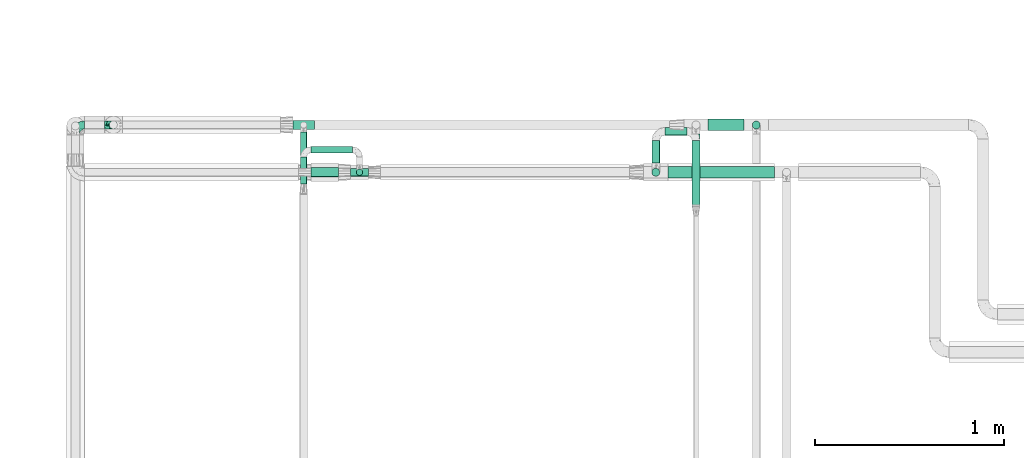
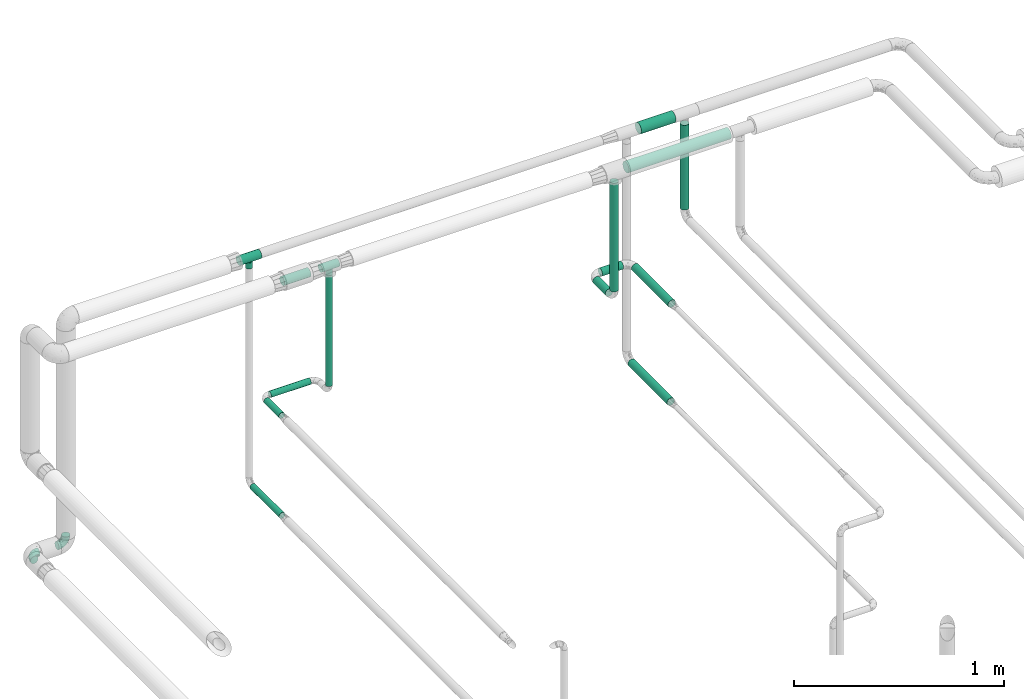
# One storey, part 580 of 824: 13 flow segments, 4 flow fittings.
"""IFC2X3 building model written with IfcOpenShell, lengths in millimetres."""

from ifc_helpers import new_model, entity, si_unit, converted_unit, derived_unit, direction, frame, origin, origin_2d_with_axis, place, context, subcontext, project, spatial, circle, extrude, faceted_brep, source, transform, mapped, material, type_object, type_shapes, element, save


model = new_model("IFC2X3")

# Units and contexts
model_context = context("Model", 3, precision=0.01, world=origin(), true_north=direction((6.12303176911189e-17, 1.0)))
body_context = subcontext(model_context, "Body", "Model", "MODEL_VIEW")
ifc_project = project(units=[si_unit("LENGTHUNIT", "METRE", prefix="MILLI"), si_unit("AREAUNIT", "SQUARE_METRE"), si_unit("VOLUMEUNIT", "CUBIC_METRE"), converted_unit("PLANEANGLEUNIT", "DEGREE", entity("IfcRatioMeasure", 0.0174532925199433), si_unit("PLANEANGLEUNIT", "RADIAN"), dimensions=[0, 0, 0, 0, 0, 0, 0]), si_unit("MASSUNIT", "GRAM", prefix="KILO"), derived_unit("MASSDENSITYUNIT", [(si_unit("MASSUNIT", "GRAM", prefix="KILO"), 1), (si_unit("LENGTHUNIT", "METRE"), -3)]), derived_unit("MOMENTOFINERTIAUNIT", [(si_unit("LENGTHUNIT", "METRE"), 4)]), si_unit("TIMEUNIT", "SECOND"), si_unit("FREQUENCYUNIT", "HERTZ"), si_unit("THERMODYNAMICTEMPERATUREUNIT", "DEGREE_CELSIUS"), derived_unit("THERMALTRANSMITTANCEUNIT", [(si_unit("MASSUNIT", "GRAM", prefix="KILO"), 1), (si_unit("THERMODYNAMICTEMPERATUREUNIT", "KELVIN"), -1), (si_unit("TIMEUNIT", "SECOND"), -3)]), derived_unit("VOLUMETRICFLOWRATEUNIT", [(si_unit("LENGTHUNIT", "METRE"), 3), (si_unit("TIMEUNIT", "SECOND"), -1)]), derived_unit("MASSFLOWRATEUNIT", [(si_unit("MASSUNIT", "GRAM", prefix="KILO"), 1), (si_unit("TIMEUNIT", "SECOND"), -1)]), derived_unit("ROTATIONALFREQUENCYUNIT", [(si_unit("TIMEUNIT", "SECOND"), -1)]), si_unit("ELECTRICCURRENTUNIT", "AMPERE"), si_unit("ELECTRICVOLTAGEUNIT", "VOLT"), si_unit("POWERUNIT", "WATT"), si_unit("FORCEUNIT", "NEWTON", prefix="KILO"), si_unit("ILLUMINANCEUNIT", "LUX"), si_unit("LUMINOUSFLUXUNIT", "LUMEN"), si_unit("LUMINOUSINTENSITYUNIT", "CANDELA"), derived_unit("USERDEFINED", [(si_unit("MASSUNIT", "GRAM", prefix="KILO"), -1), (si_unit("LENGTHUNIT", "METRE"), -2), (si_unit("TIMEUNIT", "SECOND"), 3), (si_unit("LUMINOUSFLUXUNIT", "LUMEN"), 1)]), derived_unit("LINEARVELOCITYUNIT", [(si_unit("LENGTHUNIT", "METRE"), 1), (si_unit("TIMEUNIT", "SECOND"), -1)]), si_unit("PRESSUREUNIT", "PASCAL"), derived_unit("USERDEFINED", [(si_unit("LENGTHUNIT", "METRE"), -2), (si_unit("MASSUNIT", "GRAM", prefix="KILO"), 1), (si_unit("TIMEUNIT", "SECOND"), -2)]), derived_unit("LINEARFORCEUNIT", [(si_unit("MASSUNIT", "GRAM", prefix="KILO"), 1), (si_unit("LENGTHUNIT", "METRE"), 1), (si_unit("TIMEUNIT", "SECOND"), -2), (si_unit("LENGTHUNIT", "METRE"), -1)]), derived_unit("PLANARFORCEUNIT", [(si_unit("MASSUNIT", "GRAM", prefix="KILO"), 1), (si_unit("LENGTHUNIT", "METRE"), 1), (si_unit("TIMEUNIT", "SECOND"), -2), (si_unit("LENGTHUNIT", "METRE"), -2)])], contexts=[model_context])

# Site, building, storey
site_placement = place(None, origin())
site = spatial("IfcSite", under=ifc_project, at=site_placement, CompositionType="ELEMENT")
building_placement = place(site_placement, origin())
building = spatial("IfcBuilding", under=site, at=building_placement, CompositionType="ELEMENT")
storey_placement = place(building_placement, frame((0.0, 0.0, 28200.0)))
storey = spatial("IfcBuildingStorey", under=building, at=storey_placement, CompositionType="ELEMENT", Elevation=28200.0)

# Flow segments
pipe_segment_type = type_object("IfcPipeSegmentType", PredefinedType="NOTDEFINED")
flow_segment_1_placement = place(storey_placement, frame((15048.15, 18810.97, 2242.71)))
element("IfcFlowSegment", 1, at=flow_segment_1_placement, inside=storey, type_object=pipe_segment_type, context=body_context, shape_type="SweptSolid", body=[
    extrude(circle(Radius=21.15, at=origin_2d_with_axis()), frame((22.75, 0.0, 22.75), z_axis=(0.0, 1.0, 0.0), x_axis=(1.0, 0.0, 0.0)), (0.0, 0.0, 1.0), 120.142381818539),
])
flow_segment_2_placement = place(storey_placement, frame((15118.9, 18956.37, 2242.71)))
element("IfcFlowSegment", 2, at=flow_segment_2_placement, inside=storey, type_object=pipe_segment_type, context=body_context, shape_type="SweptSolid", body=[
    extrude(circle(Radius=21.15, at=origin_2d_with_axis()), frame((0.0, 22.75, 22.75), z_axis=(1.0, 0.0, 0.0), x_axis=(0.0, -1.0, 0.0)), (0.0, 0.0, 1.0), 116.614491839044),
])
flow_segment_3_placement = place(storey_placement, frame((15260.77, 18582.97, 2242.71)))
element("IfcFlowSegment", 3, at=flow_segment_3_placement, inside=storey, type_object=pipe_segment_type, context=body_context, shape_type="SweptSolid", body=[
    extrude(circle(Radius=21.15, at=origin_2d_with_axis()), frame((22.75, 0.0, 22.75), z_axis=(0.0, 1.0, 0.0), x_axis=(-1.0, 0.0, 0.0)), (0.0, 0.0, 1.0), 348.142381818546),
])
flow_segment_4_placement = place(storey_placement, frame((13487.6, 18744.63, 2308.25)))
element("IfcFlowSegment", 4, at=flow_segment_4_placement, inside=storey, type_object=pipe_segment_type, context=body_context, shape_type="SweptSolid", body=[
    extrude(circle(Radius=16.75, at=origin_2d_with_axis()), frame((18.35, 18.35, 0.0)), (0.0, 0.0, 1.0), 643.753648623894),
])
flow_segment_5_placement = place(storey_placement, frame((13248.89, 18737.38, 2974.4)))
element("IfcFlowSegment", 5, at=flow_segment_5_placement, inside=storey, type_object=pipe_segment_type, context=body_context, shape_type="SweptSolid", body=[
    extrude(circle(Radius=24.0, at=origin_2d_with_axis()), frame((0.0, 25.6, 25.6), z_axis=(1.0, 0.0, 0.0), x_axis=(0.0, 1.0, 0.0)), (0.0, 0.0, 1.0), 145.055644500956),
])
flow_segment_6_placement = place(storey_placement, frame((13248.97, 18863.38, 2251.9)))
element("IfcFlowSegment", 6, at=flow_segment_6_placement, inside=storey, type_object=pipe_segment_type, context=body_context, shape_type="SweptSolid", body=[
    extrude(circle(Radius=16.75, at=origin_2d_with_axis()), frame((0.0, 18.35, 18.35), z_axis=(1.0, 0.0, 0.0), x_axis=(0.0, 1.0, 0.0)), (0.0, 0.0, 1.0), 218.981935169846),
])
flow_segment_7_placement = place(storey_placement, frame((13192.62, 18700.88, 2251.9)))
element("IfcFlowSegment", 7, at=flow_segment_7_placement, inside=storey, type_object=pipe_segment_type, context=body_context, shape_type="SweptSolid", body=[
    extrude(circle(Radius=16.75, at=origin_2d_with_axis()), frame((18.35, 0.0, 18.35), z_axis=(0.0, 1.0, 0.0), x_axis=(-1.0, 0.0, 0.0)), (0.0, 0.0, 1.0), 142.847515151865),
])
flow_segment_8_placement = place(storey_placement, frame((13192.62, 18697.75, 1674.32)))
element("IfcFlowSegment", 8, at=flow_segment_8_placement, inside=storey, type_object=pipe_segment_type, context=body_context, shape_type="SweptSolid", body=[
    extrude(circle(Radius=16.75, at=origin_2d_with_axis()), frame((18.35, 0.0, 18.35), z_axis=(0.0, 1.0, 0.0), x_axis=(-1.0, 0.0, 0.0)), (0.0, 0.0, 1.0), 277.053558251562),
])
flow_segment_9_placement = place(storey_placement, frame((15260.77, 18593.49, 1667.96)))
element("IfcFlowSegment", 9, at=flow_segment_9_placement, inside=storey, type_object=pipe_segment_type, context=body_context, shape_type="SweptSolid", body=[
    extrude(circle(Radius=21.15, at=origin_2d_with_axis()), frame((22.75, 0.0, 22.75), z_axis=(0.0, 1.0, 0.0), x_axis=(-1.0, 0.0, 0.0)), (0.0, 0.0, 1.0), 371.973361835637),
])
flow_segment_10_placement = place(storey_placement, frame((15048.15, 18740.23, 2313.46)))
element("IfcFlowSegment", 10, at=flow_segment_10_placement, inside=storey, type_object=pipe_segment_type, context=body_context, shape_type="SweptSolid", body=[
    extrude(circle(Radius=21.15, at=origin_2d_with_axis()), frame((22.75, 22.75, 0.0)), (0.0, 0.0, 1.0), 629.542626520971),
])
flow_segment_11_placement = place(storey_placement, frame((15578.81, 18990.05, 2450.06)))
element("IfcFlowSegment", 11, at=flow_segment_11_placement, inside=storey, type_object=pipe_segment_type, context=body_context, shape_type="SweptSolid", body=[
    extrude(circle(Radius=21.15, at=origin_2d_with_axis()), frame((22.75, 22.75, 0.0)), (0.0, 0.0, 1.0), 492.000000000014),
])
flow_segment_12_placement = place(storey_placement, frame((15347.51, 18981.87, 2968.4)))
element("IfcFlowSegment", 12, at=flow_segment_12_placement, inside=storey, type_object=pipe_segment_type, context=body_context, shape_type="SweptSolid", body=[
    extrude(circle(Radius=30.0, at=origin_2d_with_axis()), frame((0.0, 31.6, 31.6), z_axis=(1.0, 0.0, 0.0), x_axis=(0.0, -1.0, 0.0)), (0.0, 0.0, 1.0), 190.042750716787),
])
flow_segment_13_placement = place(storey_placement, frame((15134.9, 18731.38, 2968.4)))
element("IfcFlowSegment", 13, at=flow_segment_13_placement, inside=storey, type_object=pipe_segment_type, context=body_context, shape_type="SweptSolid", body=[
    extrude(circle(Radius=30.0, at=origin_2d_with_axis()), frame((0.0, 31.6, 31.6), z_axis=(1.0, 0.0, 0.0), x_axis=(0.0, -1.0, 0.0)), (0.0, 0.0, 1.0), 562.048283667767),
])

# Flow fittings
ifc_material = material()
pipe_fitting_type_1 = type_object("IfcPipeFittingType", PredefinedType="NOTDEFINED", material=ifc_material)
shared_shape_1 = source(origin(), body_context, "Body", "Brep", [
    faceted_brep([(-48.0, 10.6, -18.36), (-48.0, 5.49, -20.48), (-48.0, 0.0, -21.2), (-48.0, -5.49, -20.48), (-48.0, -10.6, -18.36), (-48.0, -14.99, -14.99), (-48.0, -18.36, -10.6), (-48.0, -20.48, -5.49), (-48.0, -21.2, 0.0), (-48.0, -20.48, 5.49), (-48.0, -18.36, 10.6), (-48.0, -14.99, 14.99), (-48.0, -10.6, 18.36), (-48.0, -5.49, 20.48), (-48.0, 0.0, 21.2), (-48.0, 5.49, 20.48), (-48.0, 10.6, 18.36), (-48.0, 14.99, 14.99), (-48.0, 18.36, 10.6), (-48.0, 20.48, 5.49), (-48.0, 21.2, 0.0), (-48.0, 20.48, -5.49), (-48.0, 18.36, -10.6), (-48.0, 14.99, -14.99), (0.0, 48.0, -21.2), (-5.49, 48.0, -20.48), (-10.6, 48.0, -18.36), (-14.99, 48.0, -14.99), (-18.36, 48.0, -10.6), (-20.48, 48.0, -5.49), (-21.2, 48.0, 0.0), (-20.48, 48.0, 5.49), (-18.36, 48.0, 10.6), (-14.99, 48.0, 14.99), (-10.6, 48.0, 18.36), (-5.49, 48.0, 20.48), (0.0, 48.0, 21.2), (5.49, 48.0, 20.48), (10.6, 48.0, 18.36), (14.99, 48.0, 14.99), (18.36, 48.0, 10.6), (20.48, 48.0, 5.49), (21.2, 48.0, 0.0), (20.48, 48.0, -5.49), (18.36, 48.0, -10.6), (14.99, 48.0, -14.99), (10.6, 48.0, -18.36), (5.49, 48.0, -20.48), (-35.25, -16.22, 12.01), (-34.76, -18.57, 0.0), (-20.87, -12.37, 10.9), (-31.49, -11.78, 15.9), (-37.0, -2.58, 20.86), (-33.89, 3.62, 21.15), (-31.81, -18.14, 6.76), (-5.78, 5.78, 17.67), (-19.42, -4.1, 17.86), (-9.6, -3.39, 13.73), (-35.44, -7.73, 19.13), (11.78, 31.49, 15.9), (-5.93, -5.46, 6.95), (-18.45, -13.78, 5.46), (-10.29, -8.43, 0.0), (-24.6, 0.55, 20.62), (-37.28, 17.94, 13.81), (-33.38, 22.85, 9.59), (-41.46, 20.06, 8.75), (-29.51, 20.45, 15.16), (-15.04, 10.79, 21.13), (-7.08, 16.98, 20.93), (-8.39, 23.51, 21.15), (-40.86, 13.03, 17.26), (-8.05, 41.26, 19.83), (-3.21, 35.97, 21.14), (8.53, 19.66, 14.74), (4.1, 19.42, 17.86), (-37.72, 22.66, 4.78), (-37.07, 8.58, 19.98), (-13.0, 5.43, 19.97), (-3.78, 13.93, 19.7), (3.02, 8.69, 13.43), (-2.27, -0.05, 10.65), (6.22, 6.99, 7.09), (-22.25, 34.6, 9.45), (18.14, 31.81, 6.76), (16.22, 35.25, 12.01), (12.37, 20.87, 10.9), (7.73, 35.44, 19.13), (-21.52, -15.93, 0.0), (2.58, 37.0, 20.86), (18.57, 34.76, 0.0), (13.78, 18.45, 5.46), (15.93, 21.52, 0.0), (-20.03, -8.54, 14.9), (-28.6, 28.6, 5.16), (-24.79, 34.6, 0.0), (-34.6, 24.79, 0.0), (-22.81, 37.41, 4.68), (-23.36, 26.33, 14.79), (-13.68, 37.05, 17.49), (-17.72, 38.12, 13.73), (-26.25, 27.3, 11.24), (-9.71, 32.34, 20.14), (-17.26, 25.6, 18.71), (-26.33, 9.99, 20.77), (-24.06, 6.05, 21.2), (-25.02, 15.46, 19.56), (-24.3, 20.72, 17.57), (-31.95, 15.23, 17.8), (-13.53, 24.7, 20.21), (-17.6, 17.6, 20.6), (-0.55, 24.6, 20.62), (-11.41, -7.48, 10.43), (0.93, -0.93, 0.0), (8.43, 10.29, 0.0), (-11.41, -7.48, -10.43), (-20.1, -8.84, -14.66), (-9.6, -3.39, -13.73), (7.73, 35.44, -19.13), (4.1, 19.42, -17.86), (-0.55, 24.6, -20.62), (-38.12, 17.72, -13.73), (-37.05, 13.68, -17.49), (-32.34, 9.71, -20.14), (-41.26, 8.05, -19.83), (-37.41, 22.81, -4.68), (-23.51, 8.39, -21.15), (-35.97, 3.21, -21.14), (-28.6, 28.6, -5.16), (-31.81, -18.14, -6.76), (-18.45, -13.78, -5.46), (-25.6, 17.26, -18.71), (-19.42, -4.1, -17.86), (-17.94, 37.28, -13.81), (-22.85, 33.38, -9.59), (-20.06, 41.46, -8.75), (-31.49, -11.78, -15.9), (-35.25, -16.22, -12.01), (8.53, 19.66, -14.74), (11.78, 31.49, -15.9), (-9.99, 26.33, -20.77), (-6.05, 24.06, -21.2), (-10.79, 15.04, -21.13), (-37.0, -2.58, -20.86), (-16.98, 7.08, -20.93), (-5.43, 13.0, -19.97), (-13.93, 3.78, -19.7), (-20.87, -12.37, -10.9), (-26.33, 23.36, -14.79), (-22.66, 37.72, -4.78), (13.78, 18.45, -5.46), (18.14, 31.81, -6.76), (-15.46, 25.02, -19.56), (-20.72, 24.3, -17.57), (16.22, 35.25, -12.01), (-13.03, 40.86, -17.26), (-8.58, 37.07, -19.98), (2.58, 37.0, -20.86), (-3.62, 33.89, -21.15), (-34.6, 22.25, -9.45), (6.22, 6.99, -7.09), (-20.45, 29.51, -15.16), (-35.44, -7.73, -19.13), (12.37, 20.87, -10.9), (-27.3, 26.25, -11.24), (-15.23, 31.95, -17.8), (-24.7, 13.53, -20.21), (-24.6, 0.55, -20.62), (-5.78, 5.78, -17.67), (-17.6, 17.6, -20.6), (3.02, 8.69, -13.43), (-5.93, -5.46, -6.95), (-2.27, -0.05, -10.65)], [[[0, 1, 2, 3, 4, 5, 6, 7, 8, 9, 10, 11, 12, 13, 14, 15, 16, 17, 18, 19, 20, 21, 22, 23]], [[24, 25, 26, 27, 28, 29, 30, 31, 32, 33, 34, 35, 36, 37, 38, 39, 40, 41, 42, 43, 44, 45, 46, 47]], [[10, 48, 11]], [[9, 8, 49]], [[48, 50, 51]], [[14, 52, 53]], [[10, 54, 48]], [[9, 54, 10]], [[55, 56, 57]], [[51, 12, 11]], [[51, 58, 12]], [[59, 39, 38]], [[60, 61, 62]], [[58, 56, 63]], [[64, 65, 66]], [[67, 65, 64]], [[68, 69, 70]], [[16, 71, 17]], [[13, 52, 14]], [[35, 72, 73]], [[14, 53, 15]], [[17, 64, 18]], [[74, 59, 75]], [[20, 19, 76]], [[66, 19, 18]], [[77, 15, 53]], [[15, 77, 16]], [[69, 78, 79]], [[80, 81, 82]], [[32, 31, 83]], [[84, 85, 86]], [[59, 87, 75]], [[61, 54, 88]], [[36, 89, 37]], [[84, 41, 40]], [[36, 35, 73]], [[90, 41, 84]], [[40, 39, 85]], [[12, 58, 13]], [[85, 84, 40]], [[91, 84, 86]], [[84, 92, 90]], [[87, 38, 37]], [[93, 56, 51]], [[65, 94, 76]], [[94, 95, 96]], [[84, 91, 92]], [[95, 97, 30]], [[98, 99, 100]], [[76, 94, 96]], [[101, 98, 83]], [[100, 99, 33]], [[102, 70, 73]], [[103, 102, 99]], [[94, 97, 95]], [[72, 99, 102]], [[72, 35, 34]], [[34, 33, 99]], [[9, 49, 54]], [[87, 59, 38]], [[104, 105, 68]], [[106, 103, 107]], [[106, 77, 104]], [[71, 64, 17]], [[108, 107, 67]], [[33, 32, 100]], [[109, 103, 110]], [[102, 109, 70]], [[89, 73, 111]], [[50, 48, 54]], [[51, 11, 48]], [[56, 58, 51]], [[88, 54, 49]], [[52, 58, 63]], [[50, 112, 93]], [[56, 55, 78]], [[39, 59, 85]], [[86, 85, 59]], [[89, 87, 37]], [[42, 41, 90]], [[111, 79, 75]], [[111, 75, 87]], [[75, 55, 80]], [[104, 77, 53]], [[71, 77, 108]], [[32, 83, 100]], [[98, 100, 83]], [[99, 98, 103]], [[106, 107, 108]], [[68, 70, 110]], [[111, 73, 70]], [[68, 110, 104]], [[68, 63, 78]], [[57, 93, 112]], [[80, 55, 57]], [[61, 50, 54]], [[80, 82, 86]], [[81, 57, 112]], [[74, 86, 59]], [[60, 113, 82]], [[82, 114, 91]], [[101, 94, 65]], [[97, 94, 83]], [[73, 89, 36]], [[87, 89, 111]], [[58, 52, 13]], [[53, 52, 63]], [[104, 53, 105]], [[106, 104, 110]], [[20, 76, 96]], [[76, 19, 66]], [[103, 106, 110]], [[77, 106, 108]], [[103, 98, 107]], [[67, 107, 98]], [[67, 98, 101]], [[108, 67, 64]], [[53, 63, 105]], [[63, 68, 105]], [[83, 31, 97]], [[30, 97, 31]], [[62, 113, 60]], [[112, 61, 60]], [[61, 88, 62]], [[86, 82, 91]], [[56, 78, 63]], [[114, 82, 113]], [[114, 92, 91]], [[79, 78, 55]], [[75, 79, 55]], [[69, 79, 111]], [[70, 69, 111]], [[78, 69, 68]], [[77, 71, 16]], [[64, 71, 108]], [[64, 66, 18]], [[76, 66, 65]], [[99, 72, 34]], [[73, 72, 102]], [[94, 101, 83]], [[67, 101, 65]], [[75, 80, 74]], [[80, 86, 74]], [[70, 109, 110]], [[102, 103, 109]], [[50, 93, 51]], [[57, 56, 93]], [[61, 112, 50]], [[81, 112, 60]], [[82, 81, 60]], [[80, 57, 81]], [[115, 116, 117]], [[118, 119, 120]], [[121, 122, 23]], [[123, 124, 122]], [[96, 125, 20]], [[123, 126, 127]], [[128, 96, 95]], [[129, 130, 88]], [[123, 122, 131]], [[116, 132, 117]], [[133, 134, 135]], [[0, 124, 1]], [[5, 136, 137]], [[138, 119, 139]], [[129, 88, 49]], [[140, 141, 142]], [[6, 5, 137]], [[46, 118, 47]], [[143, 3, 2]], [[144, 145, 146]], [[6, 129, 7]], [[129, 137, 147]], [[127, 2, 1]], [[148, 122, 121]], [[128, 125, 96]], [[134, 128, 149]], [[95, 149, 128]], [[150, 151, 92]], [[30, 29, 149]], [[152, 131, 153]], [[27, 133, 28]], [[154, 45, 44]], [[136, 5, 4]], [[27, 26, 155]], [[156, 26, 25]], [[24, 157, 158]], [[24, 47, 157]], [[22, 21, 159]], [[160, 150, 114]], [[134, 133, 161]], [[142, 144, 126]], [[46, 139, 118]], [[162, 136, 4]], [[156, 25, 158]], [[1, 124, 127]], [[115, 147, 116]], [[45, 154, 139]], [[139, 46, 45]], [[154, 163, 139]], [[162, 4, 3]], [[42, 90, 43]], [[130, 129, 147]], [[49, 7, 129]], [[43, 151, 44]], [[0, 23, 122]], [[24, 158, 25]], [[136, 162, 132]], [[135, 29, 28]], [[43, 90, 151]], [[164, 148, 159]], [[152, 156, 140]], [[155, 133, 27]], [[165, 153, 161]], [[23, 22, 121]], [[123, 131, 166]], [[123, 166, 126]], [[143, 127, 167]], [[147, 137, 136]], [[8, 7, 49]], [[129, 6, 137]], [[143, 162, 3]], [[167, 146, 132]], [[167, 132, 162]], [[132, 168, 117]], [[44, 151, 154]], [[92, 151, 90]], [[163, 154, 151]], [[119, 118, 139]], [[157, 118, 120]], [[138, 139, 163]], [[119, 168, 145]], [[140, 156, 158]], [[155, 156, 165]], [[22, 159, 121]], [[148, 121, 159]], [[122, 148, 131]], [[152, 153, 165]], [[142, 126, 169]], [[167, 127, 126]], [[142, 169, 140]], [[142, 120, 145]], [[168, 170, 117]], [[160, 171, 172]], [[115, 172, 171]], [[171, 62, 130]], [[119, 170, 168]], [[170, 163, 160]], [[150, 163, 151]], [[113, 171, 160]], [[164, 128, 134]], [[125, 128, 159]], [[127, 143, 2]], [[162, 143, 167]], [[118, 157, 47]], [[158, 157, 120]], [[140, 158, 141]], [[152, 140, 169]], [[30, 149, 95]], [[149, 29, 135]], [[131, 152, 169]], [[156, 152, 165]], [[131, 148, 153]], [[161, 153, 148]], [[161, 148, 164]], [[165, 161, 133]], [[158, 120, 141]], [[120, 142, 141]], [[159, 21, 125]], [[20, 125, 21]], [[115, 130, 147]], [[114, 113, 160]], [[62, 171, 113]], [[62, 88, 130]], [[160, 163, 150]], [[150, 92, 114]], [[119, 145, 120]], [[146, 145, 168]], [[132, 146, 168]], [[144, 146, 167]], [[126, 144, 167]], [[145, 144, 142]], [[156, 155, 26]], [[133, 155, 165]], [[133, 135, 28]], [[149, 135, 134]], [[122, 124, 0]], [[127, 124, 123]], [[128, 164, 159]], [[161, 164, 134]], [[163, 170, 138]], [[170, 119, 138]], [[131, 169, 166]], [[126, 166, 169]], [[147, 136, 116]], [[132, 116, 136]], [[172, 115, 117]], [[130, 115, 171]], [[117, 170, 172]], [[160, 172, 170]]]),
])
type_shapes(pipe_fitting_type_1, [shared_shape_1])
for number, where, z_axis, x_axis in (
    (14, (12205.95, 19013.47, 1694.27), (0.0, 1.0, 0.0), (0.0, 0.0, -1.0)),
    (15, (12005.95, 19013.47, 1694.27), (0.0, 0.0, 1.0), (-1.0, 0.0, 0.0)),
):
    element("IfcFlowFitting", number, at=place(storey_placement, frame(where, z_axis=z_axis, x_axis=x_axis)), inside=storey, type_object=pipe_fitting_type_1, material=ifc_material, context=body_context, shape_type="MappedRepresentation", body=[
        mapped(shared_shape_1, transform((0.0, 0.0, 0.0), scale=1.0)),
    ])
pipe_fitting_type_2 = type_object("IfcPipeFittingType", PredefinedType="NOTDEFINED", material=ifc_material)
shared_shape_2 = source(origin(), body_context, "Body", "Brep", [
    faceted_brep([(-48.0, 10.6, -18.36), (-48.0, 5.49, -20.48), (-48.0, 0.0, -21.2), (-48.0, -5.49, -20.48), (-48.0, -10.6, -18.36), (-48.0, -14.99, -14.99), (-48.0, -18.36, -10.6), (-48.0, -20.48, -5.49), (-48.0, -21.2, 0.0), (-48.0, -20.48, 5.49), (-48.0, -18.36, 10.6), (-48.0, -14.99, 14.99), (-48.0, -10.6, 18.36), (-48.0, -5.49, 20.48), (-48.0, 0.0, 21.2), (-48.0, 5.49, 20.48), (-48.0, 10.6, 18.36), (-48.0, 14.99, 14.99), (-48.0, 18.36, 10.6), (-48.0, 20.48, 5.49), (-48.0, 21.2, 0.0), (-48.0, 20.48, -5.49), (-48.0, 18.36, -10.6), (-48.0, 14.99, -14.99), (48.0, 0.0, -21.2), (48.0, 5.49, -20.48), (48.0, 10.6, -18.36), (48.0, 14.99, -14.99), (48.0, 18.36, -10.6), (48.0, 20.48, -5.49), (48.0, 21.2, 0.0), (48.0, 20.48, 5.49), (48.0, 18.36, 10.6), (48.0, 14.99, 14.99), (48.0, 10.6, 18.36), (48.0, 5.49, 20.48), (48.0, 0.0, 21.2), (48.0, -5.49, 20.48), (48.0, -10.6, 18.36), (48.0, -14.99, 14.99), (48.0, -18.36, 10.6), (48.0, -20.48, 5.49), (48.0, -21.2, 0.0), (48.0, -20.48, -5.49), (48.0, -18.36, -10.6), (48.0, -14.99, -14.99), (48.0, -10.6, -18.36), (48.0, -5.49, -20.48), (16.85, -21.2, 0.0), (-16.85, -21.2, 0.0), (15.74, -20.33, 6.01), (16.3, -20.76, 3.01), (12.78, -18.13, 10.98), (8.5, -15.42, 14.55), (3.07, -13.23, 16.57), (-16.3, -20.76, 3.01), (-15.74, -20.33, 6.01), (-8.5, -15.42, 14.55), (-3.07, -13.23, 16.57), (-12.78, -18.13, 10.98), (0.0, -13.23, 16.57), (3.07, -13.23, -16.57), (12.78, -18.13, -10.98), (8.5, -15.42, -14.55), (15.74, -20.33, -6.01), (16.3, -20.76, -3.01), (-3.07, -13.23, -16.57), (-8.5, -15.42, -14.55), (-12.78, -18.13, -10.98), (-15.74, -20.33, -6.01), (-16.3, -20.76, -3.01), (0.0, -13.23, -16.57), (4.36, -48.0, -16.28), (8.43, -48.0, -14.59), (11.91, -48.0, -11.91), (14.59, -48.0, -8.43), (16.28, -48.0, -4.36), (16.85, -48.0, 0.0), (16.28, -48.0, 4.36), (14.59, -48.0, 8.42), (11.91, -48.0, 11.91), (8.43, -48.0, 14.59), (4.36, -48.0, 16.28), (0.0, -48.0, 16.85), (-4.36, -48.0, 16.28), (-8.42, -48.0, 14.59), (-11.91, -48.0, 11.91), (-14.59, -48.0, 8.42), (-16.28, -48.0, 4.36), (-16.85, -48.0, 0.0), (-16.28, -48.0, -4.36), (-14.59, -48.0, -8.43), (-11.91, -48.0, -11.91), (-8.42, -48.0, -14.59), (-4.36, -48.0, -16.28), (0.0, -48.0, -16.85)], [[[0, 1, 2, 3, 4, 5, 6, 7, 8, 9, 10, 11, 12, 13, 14, 15, 16, 17, 18, 19, 20, 21, 22, 23]], [[24, 25, 26, 27, 28, 29, 30, 31, 32, 33, 34, 35, 36, 37, 38, 39, 40, 41, 42, 43, 44, 45, 46, 47]], [[42, 41, 48]], [[9, 8, 49]], [[41, 50, 51, 48]], [[41, 40, 50]], [[40, 39, 52]], [[53, 52, 39]], [[54, 53, 39]], [[39, 38, 54]], [[40, 52, 50]], [[9, 49, 55, 56]], [[56, 10, 9]], [[57, 58, 11]], [[10, 59, 11]], [[59, 10, 56]], [[11, 59, 57]], [[58, 12, 11]], [[12, 58, 60, 54]], [[14, 13, 37, 36]], [[13, 12, 38, 37]], [[15, 14, 36, 35]], [[32, 31, 19, 18]], [[17, 16, 34, 33]], [[18, 17, 33, 32]], [[35, 34, 16, 15]], [[20, 19, 31, 30]], [[38, 12, 54]], [[29, 28, 22, 21]], [[28, 27, 23, 22]], [[30, 29, 21, 20]], [[24, 47, 3, 2]], [[25, 1, 0, 26]], [[2, 1, 25, 24]], [[26, 0, 23, 27]], [[4, 3, 47, 46]], [[46, 61, 4]], [[45, 62, 63]], [[62, 45, 44]], [[63, 61, 45]], [[45, 61, 46]], [[43, 42, 48]], [[7, 49, 8]], [[43, 64, 44]], [[43, 48, 65, 64]], [[44, 64, 62]], [[66, 67, 5]], [[5, 68, 6]], [[68, 5, 67]], [[66, 5, 4]], [[7, 69, 70, 49]], [[69, 7, 6]], [[69, 6, 68]], [[4, 61, 71, 66]], [[72, 73, 74, 75, 76, 77, 78, 79, 80, 81, 82, 83, 84, 85, 86, 87, 88, 89, 90, 91, 92, 93, 94, 95]], [[51, 77, 48]], [[57, 86, 85]], [[86, 59, 87]], [[57, 85, 84]], [[55, 49, 89]], [[89, 88, 55]], [[88, 87, 56]], [[88, 56, 55]], [[59, 56, 87]], [[86, 57, 59]], [[51, 50, 78]], [[84, 58, 57]], [[83, 54, 60, 58]], [[53, 82, 81]], [[80, 53, 81]], [[50, 79, 78]], [[80, 79, 52]], [[54, 83, 82]], [[82, 53, 54]], [[83, 58, 84]], [[53, 80, 52]], [[52, 79, 50]], [[77, 51, 78]], [[76, 65, 77]], [[95, 61, 72]], [[70, 89, 49]], [[76, 64, 65]], [[76, 75, 64]], [[74, 62, 75]], [[65, 48, 77]], [[64, 75, 62]], [[73, 72, 63]], [[63, 62, 74]], [[63, 72, 61]], [[63, 74, 73]], [[95, 66, 71, 61]], [[67, 94, 93]], [[92, 67, 93]], [[69, 91, 90]], [[92, 91, 68]], [[66, 95, 94]], [[94, 67, 66]], [[67, 92, 68]], [[68, 91, 69]], [[89, 70, 90]], [[70, 69, 90]]]),
])
type_shapes(pipe_fitting_type_2, [shared_shape_2])
flow_fitting_1_placement = place(storey_placement, frame((13505.95, 18762.97, 3000.0), z_axis=(0.0, 1.0, 0.0), x_axis=(-1.0, 0.0, 0.0)))
element("IfcFlowFitting", 16, at=flow_fitting_1_placement, inside=storey, type_object=pipe_fitting_type_2, material=ifc_material, context=body_context, shape_type="MappedRepresentation", body=[
    mapped(shared_shape_2, transform((0.0, 0.0, 0.0), scale=1.0)),
])
pipe_fitting_type_3 = type_object("IfcPipeFittingType", PredefinedType="NOTDEFINED", material=ifc_material)
shared_shape_3 = source(origin(), body_context, "Body", "Brep", [
    faceted_brep([(-57.0, 12.07, -20.91), (-57.0, 6.25, -23.33), (-57.0, 0.0, -24.15), (-57.0, -6.25, -23.33), (-57.0, -12.08, -20.91), (-57.0, -17.08, -17.08), (-57.0, -20.91, -12.08), (-57.0, -23.33, -6.25), (-57.0, -24.15, 0.0), (-57.0, -23.33, 6.25), (-57.0, -20.91, 12.07), (-57.0, -17.08, 17.08), (-57.0, -12.08, 20.91), (-57.0, -6.25, 23.33), (-57.0, 0.0, 24.15), (-57.0, 6.25, 23.33), (-57.0, 12.07, 20.91), (-57.0, 17.08, 17.08), (-57.0, 20.91, 12.07), (-57.0, 23.33, 6.25), (-57.0, 24.15, 0.0), (-57.0, 23.33, -6.25), (-57.0, 20.91, -12.08), (-57.0, 17.08, -17.08), (57.0, 0.0, -24.15), (57.0, 6.25, -23.33), (57.0, 12.07, -20.91), (57.0, 17.08, -17.08), (57.0, 20.91, -12.08), (57.0, 23.33, -6.25), (57.0, 24.15, 0.0), (57.0, 23.33, 6.25), (57.0, 20.91, 12.07), (57.0, 17.08, 17.08), (57.0, 12.07, 20.91), (57.0, 6.25, 23.33), (57.0, 0.0, 24.15), (57.0, -6.25, 23.33), (57.0, -12.08, 20.91), (57.0, -17.08, 17.08), (57.0, -20.91, 12.07), (57.0, -23.33, 6.25), (57.0, -24.15, 0.0), (57.0, -23.33, -6.25), (57.0, -20.91, -12.08), (57.0, -17.08, -17.08), (57.0, -12.08, -20.91), (57.0, -6.25, -23.33), (15.77, -23.41, 5.93), (16.31, -23.78, 2.97), (16.85, -24.15, 0.0), (12.83, -21.54, 10.92), (8.5, -19.28, 14.55), (3.03, -17.56, 16.58), (-3.03, -17.56, 16.58), (0.0, -17.56, 16.58), (-16.85, -24.15, 0.0), (-16.31, -23.78, 2.96), (-15.77, -23.41, 5.93), (-12.84, -21.54, 10.92), (-8.5, -19.28, 14.55), (3.03, -17.56, -16.58), (8.5, -19.28, -14.55), (12.83, -21.54, -10.92), (0.0, -17.56, -16.58), (-3.03, -17.56, -16.58), (15.77, -23.41, -5.93), (16.31, -23.78, -2.97), (-8.5, -19.28, -14.55), (-12.84, -21.54, -10.92), (-15.77, -23.41, -5.93), (-16.31, -23.78, -2.96), (11.91, -57.0, -11.91), (14.59, -57.0, -8.43), (16.28, -57.0, -4.36), (16.85, -57.0, 0.0), (16.28, -57.0, 4.36), (14.59, -57.0, 8.42), (11.91, -57.0, 11.91), (8.43, -57.0, 14.59), (4.36, -57.0, 16.28), (0.0, -57.0, 16.85), (-4.36, -57.0, 16.28), (-8.42, -57.0, 14.59), (-11.91, -57.0, 11.91), (-14.59, -57.0, 8.42), (-16.28, -57.0, 4.36), (-16.85, -57.0, 0.0), (-16.28, -57.0, -4.36), (-14.59, -57.0, -8.43), (-11.91, -57.0, -11.91), (-8.42, -57.0, -14.59), (-4.36, -57.0, -16.28), (0.0, -57.0, -16.85), (4.36, -57.0, -16.28), (8.43, -57.0, -14.59)], [[[0, 1, 2, 3, 4, 5, 6, 7, 8, 9, 10, 11, 12, 13, 14, 15, 16, 17, 18, 19, 20, 21, 22, 23]], [[24, 25, 26, 27, 28, 29, 30, 31, 32, 33, 34, 35, 36, 37, 38, 39, 40, 41, 42, 43, 44, 45, 46, 47]], [[42, 41, 48]], [[42, 48, 49, 50]], [[41, 51, 48]], [[40, 39, 52]], [[52, 51, 40]], [[53, 52, 39]], [[12, 54, 55, 53]], [[40, 51, 41]], [[8, 56, 57, 58]], [[9, 8, 58]], [[58, 59, 9]], [[60, 54, 11]], [[60, 10, 59]], [[10, 60, 11]], [[59, 10, 9]], [[11, 54, 12]], [[53, 39, 38]], [[14, 13, 37, 36]], [[13, 12, 38, 37]], [[15, 14, 36, 35]], [[32, 31, 19, 18]], [[17, 16, 34, 33]], [[18, 17, 33, 32]], [[35, 34, 16, 15]], [[20, 19, 31, 30]], [[38, 12, 53]], [[29, 28, 22, 21]], [[28, 27, 23, 22]], [[30, 29, 21, 20]], [[24, 47, 3, 2]], [[1, 0, 26, 25]], [[2, 1, 25, 24]], [[27, 26, 0, 23]], [[4, 3, 47, 46]], [[46, 61, 4]], [[45, 44, 62]], [[62, 61, 45]], [[44, 63, 62]], [[4, 61, 64, 65]], [[43, 42, 66]], [[66, 63, 43]], [[42, 50, 67, 66]], [[43, 63, 44]], [[65, 68, 5]], [[6, 5, 68]], [[68, 69, 6]], [[5, 4, 65]], [[69, 70, 7]], [[70, 8, 7]], [[8, 70, 71, 56]], [[69, 7, 6]], [[61, 46, 45]], [[72, 73, 74, 75, 76, 77, 78, 79, 80, 81, 82, 83, 84, 85, 86, 87, 88, 89, 90, 91, 92, 93, 94, 95]], [[58, 86, 85]], [[60, 84, 83]], [[85, 84, 59]], [[60, 83, 82]], [[57, 87, 86]], [[56, 87, 57]], [[86, 58, 57]], [[59, 58, 85]], [[84, 60, 59]], [[49, 75, 50]], [[82, 54, 60]], [[81, 53, 55, 54]], [[52, 80, 79]], [[78, 52, 79]], [[48, 77, 76]], [[78, 77, 51]], [[53, 81, 80]], [[80, 52, 53]], [[81, 54, 82]], [[52, 78, 51]], [[51, 77, 48]], [[49, 48, 76]], [[75, 49, 76]], [[74, 67, 75]], [[71, 70, 88]], [[93, 61, 94]], [[71, 87, 56]], [[74, 66, 67]], [[66, 74, 73]], [[63, 73, 72]], [[67, 50, 75]], [[66, 73, 63]], [[95, 94, 62]], [[62, 63, 72]], [[62, 94, 61]], [[62, 72, 95]], [[93, 65, 64, 61]], [[68, 92, 91]], [[90, 68, 91]], [[70, 89, 88]], [[90, 89, 69]], [[65, 93, 92]], [[92, 68, 65]], [[68, 90, 69]], [[69, 89, 70]], [[87, 71, 88]]]),
])
type_shapes(pipe_fitting_type_3, [shared_shape_3])
flow_fitting_2_placement = place(storey_placement, frame((13210.97, 19012.8, 2999.06), z_axis=(0.0, 1.0, 0.0), x_axis=(-1.0, 0.0, 0.0)))
element("IfcFlowFitting", 17, at=flow_fitting_2_placement, inside=storey, type_object=pipe_fitting_type_3, material=ifc_material, context=body_context, shape_type="MappedRepresentation", body=[
    mapped(shared_shape_3, transform((0.0, 0.0, 0.0), scale=1.0)),
])

save(model, "model.ifc")
